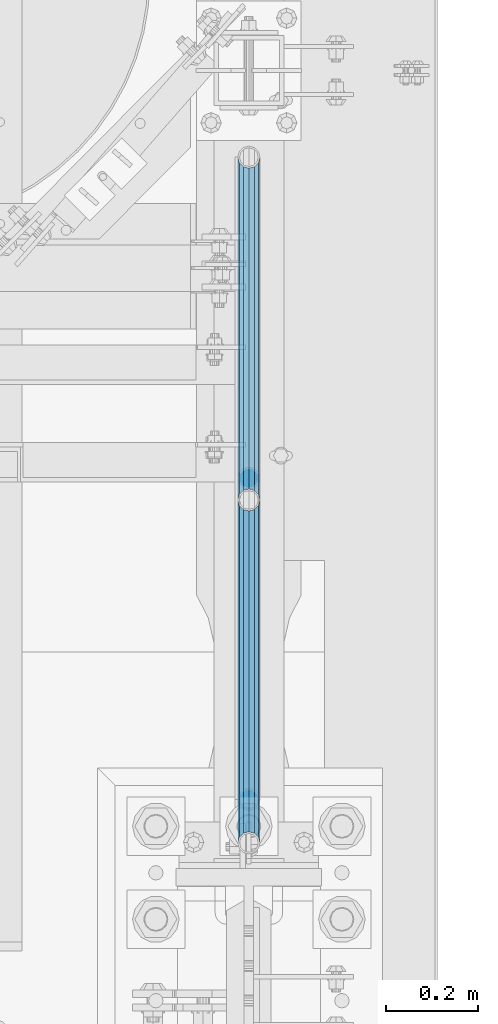
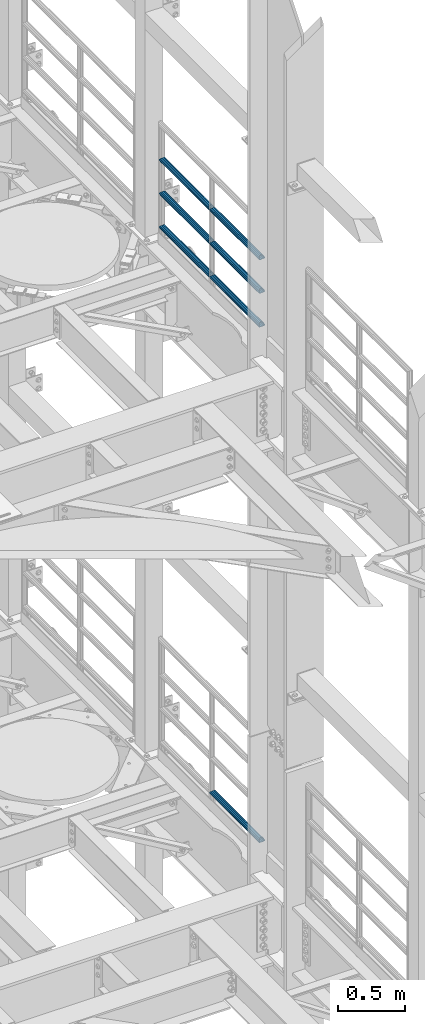
# One storey, part 1274 of 1876: 7 beams, 2 elements without a shape of their own.
"""IFC2X3 building model written with IfcOpenShell, lengths in millimetres."""

from ifc_helpers import new_model, si_unit, frame, origin_with_axes, place, context, subcontext, project, spatial, faceted_brep, material, type_object, element, aggregate, save


model = new_model("IFC2X3")

# Units and contexts
model_context = context("Model", 3, precision=1e-05, world=origin_with_axes())
body_context = subcontext(model_context, "Body", "Model", "MODEL_VIEW")
ifc_project = project(units=[si_unit("LENGTHUNIT", "METRE", prefix="MILLI"), si_unit("AREAUNIT", "SQUARE_METRE"), si_unit("VOLUMEUNIT", "CUBIC_METRE"), si_unit("MASSUNIT", "GRAM", prefix="KILO"), si_unit("TIMEUNIT", "SECOND"), si_unit("PLANEANGLEUNIT", "RADIAN"), si_unit("SOLIDANGLEUNIT", "STERADIAN"), si_unit("THERMODYNAMICTEMPERATUREUNIT", "DEGREE_CELSIUS"), si_unit("LUMINOUSINTENSITYUNIT", "LUMEN")], contexts=[model_context])

# Site, building, storey
site_placement = place(None, origin_with_axes())
site = spatial("IfcSite", under=ifc_project, at=site_placement, CompositionType="ELEMENT")
building_placement = place(site_placement, origin_with_axes())
building = spatial("IfcBuilding", under=site, at=building_placement, Name="Undefined", CompositionType="ELEMENT")
storey_placement = place(building_placement, origin_with_axes())
storey = spatial("IfcBuildingStorey", under=building, at=storey_placement, Name="Undefined", CompositionType="ELEMENT", Elevation=0.0)

# Assembly, beams
assembly_1_placement = place(storey_placement, origin_with_axes())
assembly_1 = element("IfcElementAssembly", 1, at=assembly_1_placement, inside=storey, Name="RAIL", AssemblyPlace="NOTDEFINED", PredefinedType="RIGID_FRAME")
ifc_material = material()
beam_type = type_object("IfcBeamType", Name="PIPE1-1/2SCH40", PredefinedType="NOTDEFINED")
beam_1_placement = place(assembly_1_placement, frame((7620.0, 2617.7875, 18145.125), z_axis=(0.0, 0.0, 1.0), x_axis=(0.0, -1.0, 0.0)))
beam_1 = element("IfcBeam", 2, at=beam_1_placement, type_object=beam_type, material=ifc_material, Name="RAIL", ObjectType="PIPE1-1/2SCH40", context=body_context, shape_type="Brep", body=[
    faceted_brep([(728.085307006683, -12.0649999999996, 20.8971929933177), (728.085307006683, -12.0649999999996, 15.8661214311796), (727.591878568821, -10.2235000000001, 17.7076214311819), (724.852500000002, 0.0, 20.4470000000001), (724.852500000002, 0.0, 24.130000000001), (727.591878568821, 10.2235000000001, 17.7076214311819), (728.085307006683, 12.0649999999996, 15.8661214311796), (728.085307006683, 12.0649999999996, 20.8971929933177), (748.982500000002, 24.1300000000001, 0.0), (736.917500000002, 20.8971929933186, 12.0649999999987), (736.917500000002, 20.8971929933186, -12.0649999999987), (733.727928437864, 17.7076214311801, 10.2235000000001), (736.467307006683, 20.4470000000001, 0.0), (733.727928437864, 17.7076214311801, -10.2235000000001), (728.085307006683, 12.0649999999996, -15.8661214311796), (728.085307006683, 12.0649999999996, -20.8971929933177), (727.591878568821, 10.2235000000001, -17.7076214311819), (724.852500000002, 0.0, -20.4470000000001), (724.852500000002, 0.0, -24.130000000001), (728.085307006683, -12.0649999999996, -15.8661214311796), (728.085307006683, -12.0649999999996, -20.8971929933177), (727.591878568821, -10.2235000000001, -17.7076214311819), (748.982500000002, -24.1300000000001, 0.0), (736.917500000002, -20.8971929933186, -12.0649999999987), (736.917500000002, -20.8971929933186, 12.0649999999987), (733.727928437864, -17.7076214311801, -10.2235000000001), (736.467307006683, -20.4470000000001, 0.0), (733.727928437864, -17.7076214311801, 10.2235000000001), (12.0650000000064, -20.8971929933177, -12.0649999999987), (20.8971929933249, -12.0650000000005, -20.8971929933177), (0.0, 24.1299999999992, 0.0), (12.0650000000064, 20.8971929933177, -12.0649999999987), (12.0650000000064, 20.8971929933177, 12.0649999999987), (20.8971929933249, 12.0650000000005, 20.8971929933177), (24.1300000000064, 0.0, 24.130000000001), (20.8971929933249, 12.0650000000005, -20.8971929933177), (24.1300000000063, 0.0, -24.130000000001), (24.1300000000063, 0.0, -20.4470000000001), (20.8971929933249, -12.0650000000005, -15.8661214311796), (21.3906214311868, -10.2235000000001, -17.7076214311819), (21.3906214311868, 10.2235000000001, -17.7076214311819), (20.8971929933249, 12.0650000000005, -15.8661214311796), (15.2545715621445, 17.7076214311801, -10.2235000000001), (12.5151929933249, 20.4470000000001, 0.0), (15.2545715621445, 17.7076214311801, 10.2235000000001), (20.8971929933249, 12.0650000000005, 15.8661214311796), (21.3906214311868, 10.2235000000001, 17.7076214311819), (24.1300000000064, 0.0, 20.4470000000001), (21.3906214311868, -10.2235000000001, 17.7076214311819), (20.8971929933249, -12.0650000000005, 15.8661214311796), (20.8971929933249, -12.0650000000005, 20.8971929933177), (12.0650000000064, -20.8971929933177, 12.0649999999987), (0.0, -24.1299999999992, 0.0), (15.2545715621445, -17.7076214311801, 10.2235000000001), (12.5151929933249, -20.4470000000001, 0.0), (15.2545715621445, -17.7076214311801, -10.2235000000001)], [[[0, 1, 2, 3, 4]], [[4, 3, 5, 6, 7]], [[8, 9, 10]], [[7, 6, 11, 12, 13, 14, 15, 10, 9]], [[16, 17, 18, 15, 14]], [[19, 20, 18, 17, 21]], [[22, 23, 24]], [[24, 23, 20, 19, 25, 26, 27, 1, 0]], [[28, 29, 20, 23]], [[30, 31, 32]], [[33, 34, 4, 7]], [[32, 33, 7, 9]], [[30, 32, 9, 8]], [[31, 30, 8, 10]], [[35, 31, 10, 15]], [[36, 35, 15, 18]], [[29, 36, 18, 20]], [[37, 36, 29, 38, 39]], [[40, 41, 35, 36, 37]], [[32, 31, 35, 41, 42, 43, 44, 45, 33]], [[33, 45, 46, 47, 34]], [[34, 47, 48, 49, 50]], [[34, 50, 0, 4]], [[50, 51, 24, 0]], [[51, 52, 22, 24]], [[52, 28, 23, 22]], [[51, 28, 52]], [[50, 49, 53, 54, 55, 38, 29, 28, 51]], [[55, 54, 26, 25]], [[21, 39, 38, 55, 25, 19]], [[37, 39, 21, 17]], [[40, 37, 17, 16]], [[42, 41, 40, 16, 14, 13]], [[43, 42, 13, 12]], [[44, 43, 12, 11]], [[5, 46, 45, 44, 11, 6]], [[47, 46, 5, 3]], [[48, 47, 3, 2]], [[53, 49, 48, 2, 1, 27]], [[54, 53, 27, 26]]]),
])
beam_2_placement = place(assembly_1_placement, frame((7620.0, 3366.77, 18145.125), z_axis=(0.0, 0.0, 1.0), x_axis=(0.0, -1.0, 0.0)))
beam_2 = element("IfcBeam", 3, at=beam_2_placement, type_object=beam_type, material=ifc_material, Name="RAIL", ObjectType="PIPE1-1/2SCH40", context=body_context, shape_type="Brep", body=[
    faceted_brep([(728.085307006683, -12.0649999999996, 20.8971929933177), (728.085307006683, -12.0649999999996, 15.8661214311796), (727.591878568821, -10.2235000000001, 17.7076214311819), (724.852500000002, 0.0, 20.4470000000001), (724.852500000002, 0.0, 24.130000000001), (727.591878568821, 10.2235000000001, 17.7076214311819), (728.085307006683, 12.0649999999996, 15.8661214311796), (728.085307006683, 12.0649999999996, 20.8971929933177), (748.982500000002, 24.1300000000001, 0.0), (736.917500000002, 20.8971929933186, 12.0649999999987), (736.917500000002, 20.8971929933186, -12.0649999999987), (733.727928437864, 17.7076214311801, 10.2235000000001), (736.467307006683, 20.4470000000001, 0.0), (733.727928437864, 17.7076214311801, -10.2235000000001), (728.085307006683, 12.0649999999996, -15.8661214311796), (728.085307006683, 12.0649999999996, -20.8971929933177), (727.591878568821, 10.2235000000001, -17.7076214311819), (724.852500000002, 0.0, -20.4470000000001), (724.852500000002, 0.0, -24.130000000001), (728.085307006683, -12.0649999999996, -15.8661214311796), (728.085307006683, -12.0649999999996, -20.8971929933177), (727.591878568821, -10.2235000000001, -17.7076214311819), (748.982500000002, -24.1300000000001, 0.0), (736.917500000002, -20.8971929933186, -12.0649999999987), (736.917500000002, -20.8971929933186, 12.0649999999987), (733.727928437864, -17.7076214311801, -10.2235000000001), (736.467307006683, -20.4470000000001, 0.0), (733.727928437864, -17.7076214311801, 10.2235000000001), (12.0650000000064, -20.8971929933177, -12.0649999999987), (20.8971929933249, -12.0650000000005, -20.8971929933177), (0.0, 24.1299999999992, 0.0), (12.0650000000064, 20.8971929933177, -12.0649999999987), (12.0650000000064, 20.8971929933177, 12.0649999999987), (20.8971929933249, 12.0650000000005, 20.8971929933177), (24.1300000000064, 0.0, 24.130000000001), (20.8971929933249, 12.0650000000005, -20.8971929933177), (24.1300000000063, 0.0, -24.130000000001), (24.1300000000063, 0.0, -20.4470000000001), (20.8971929933249, -12.0650000000005, -15.8661214311796), (21.3906214311868, -10.2235000000001, -17.7076214311819), (21.3906214311868, 10.2235000000001, -17.7076214311819), (20.8971929933249, 12.0650000000005, -15.8661214311796), (15.2545715621445, 17.7076214311801, -10.2235000000001), (12.5151929933249, 20.4470000000001, 0.0), (15.2545715621445, 17.7076214311801, 10.2235000000001), (20.8971929933249, 12.0650000000005, 15.8661214311796), (21.3906214311868, 10.2235000000001, 17.7076214311819), (24.1300000000064, 0.0, 20.4470000000001), (21.3906214311868, -10.2235000000001, 17.7076214311819), (20.8971929933249, -12.0650000000005, 15.8661214311796), (20.8971929933249, -12.0650000000005, 20.8971929933177), (12.0650000000064, -20.8971929933177, 12.0649999999987), (0.0, -24.1299999999992, 0.0), (15.2545715621445, -17.7076214311801, 10.2235000000001), (12.5151929933249, -20.4470000000001, 0.0), (15.2545715621445, -17.7076214311801, -10.2235000000001)], [[[0, 1, 2, 3, 4]], [[4, 3, 5, 6, 7]], [[8, 9, 10]], [[7, 6, 11, 12, 13, 14, 15, 10, 9]], [[16, 17, 18, 15, 14]], [[19, 20, 18, 17, 21]], [[22, 23, 24]], [[24, 23, 20, 19, 25, 26, 27, 1, 0]], [[28, 29, 20, 23]], [[30, 31, 32]], [[33, 34, 4, 7]], [[32, 33, 7, 9]], [[30, 32, 9, 8]], [[31, 30, 8, 10]], [[35, 31, 10, 15]], [[36, 35, 15, 18]], [[29, 36, 18, 20]], [[37, 36, 29, 38, 39]], [[40, 41, 35, 36, 37]], [[32, 31, 35, 41, 42, 43, 44, 45, 33]], [[33, 45, 46, 47, 34]], [[34, 47, 48, 49, 50]], [[34, 50, 0, 4]], [[50, 51, 24, 0]], [[51, 52, 22, 24]], [[52, 28, 23, 22]], [[51, 28, 52]], [[50, 49, 53, 54, 55, 38, 29, 28, 51]], [[55, 54, 26, 25]], [[21, 39, 38, 55, 25, 19]], [[37, 39, 21, 17]], [[40, 37, 17, 16]], [[42, 41, 40, 16, 14, 13]], [[43, 42, 13, 12]], [[44, 43, 12, 11]], [[5, 46, 45, 44, 11, 6]], [[47, 46, 5, 3]], [[48, 47, 3, 2]], [[53, 49, 48, 2, 1, 27]], [[54, 53, 27, 26]]]),
])
beam_3_placement = place(assembly_1_placement, frame((7620.0, 1868.805, 18449.925), z_axis=(0.0, 0.0, -1.0), x_axis=(0.0, 1.0, 0.0)))
beam_3 = element("IfcBeam", 4, at=beam_3_placement, type_object=beam_type, material=ifc_material, Name="RAIL", ObjectType="PIPE1-1/2SCH40", context=body_context, shape_type="Brep", body=[
    faceted_brep([(0.0, 24.1299999999992, 0.0), (12.0650000000064, 20.8971929933177, -12.0649999999987), (12.0650000000064, 20.8971929933177, 12.0649999999987), (12.0650000000064, -20.8971929933177, 12.0649999999987), (12.0650000000064, -20.8971929933177, -12.0649999999987), (0.0, -24.1299999999992, 0.0), (20.8971929933249, -12.0650000000005, 20.8971929933177), (20.8971929933249, -12.0650000000005, 15.8661214311796), (15.2545715621445, -17.7076214311801, 10.2235000000001), (12.5151929933249, -20.4470000000001, 0.0), (15.2545715621445, -17.7076214311801, -10.2235000000001), (20.8971929933249, -12.0650000000005, -15.8661214311796), (20.8971929933249, -12.0650000000005, -20.8971929933177), (24.1300000000063, 0.0, -20.4470000000001), (24.1300000000063, 0.0, -24.130000000001), (21.3906214311868, -10.2235000000001, -17.7076214311819), (21.3906214311868, 10.2235000000001, -17.7076214311819), (20.8971929933249, 12.0650000000005, -15.8661214311796), (20.8971929933249, 12.0650000000005, -20.8971929933177), (15.2545715621445, 17.7076214311801, -10.2235000000001), (12.5151929933249, 20.4470000000001, 0.0), (15.2545715621445, 17.7076214311801, 10.2235000000001), (20.8971929933249, 12.0650000000005, 15.8661214311796), (20.8971929933249, 12.0650000000005, 20.8971929933177), (21.3906214311868, 10.2235000000001, 17.7076214311819), (24.1300000000064, 0.0, 20.4470000000001), (24.1300000000064, 0.0, 24.130000000001), (21.3906214311868, -10.2235000000001, 17.7076214311819), (748.982500000002, 24.1300000000001, 0.0), (736.917500000002, 20.8971929933186, -12.0649999999987), (728.085307006683, 12.0649999999996, -20.8971929933177), (748.982500000002, -24.1300000000001, 0.0), (736.917500000002, -20.8971929933186, -12.0649999999987), (736.917500000002, -20.8971929933186, 12.0649999999987), (728.085307006683, -12.0649999999996, 20.8971929933177), (728.085307006683, -12.0649999999996, -20.8971929933177), (724.852500000002, 0.0, -24.130000000001), (727.591878568821, 10.2235000000001, -17.7076214311819), (724.852500000002, 0.0, -20.4470000000001), (728.085307006683, 12.0649999999996, -15.8661214311796), (728.085307006683, -12.0649999999996, -15.8661214311796), (727.591878568821, -10.2235000000001, -17.7076214311819), (733.727928437864, -17.7076214311801, -10.2235000000001), (736.467307006683, -20.4470000000001, 0.0), (733.727928437864, -17.7076214311801, 10.2235000000001), (728.085307006683, -12.0649999999996, 15.8661214311796), (727.591878568821, -10.2235000000001, 17.7076214311819), (724.852500000002, 0.0, 20.4470000000001), (724.852500000002, 0.0, 24.130000000001), (728.085307006683, 12.0649999999996, 20.8971929933177), (736.917500000002, 20.8971929933186, 12.0649999999987), (728.085307006683, 12.0649999999996, 15.8661214311796), (733.727928437864, 17.7076214311801, 10.2235000000001), (736.467307006683, 20.4470000000001, 0.0), (733.727928437864, 17.7076214311801, -10.2235000000001), (727.591878568821, 10.2235000000001, 17.7076214311819)], [[[0, 1, 2]], [[3, 4, 5]], [[6, 7, 8, 9, 10, 11, 12, 4, 3]], [[13, 14, 12, 11, 15]], [[16, 17, 18, 14, 13]], [[2, 1, 18, 17, 19, 20, 21, 22, 23]], [[23, 22, 24, 25, 26]], [[26, 25, 27, 7, 6]], [[1, 0, 28, 29]], [[18, 1, 29, 30]], [[31, 32, 33]], [[6, 3, 33, 34]], [[3, 5, 31, 33]], [[5, 4, 32, 31]], [[4, 12, 35, 32]], [[12, 14, 36, 35]], [[14, 18, 30, 36]], [[37, 38, 36, 30, 39]], [[40, 35, 36, 38, 41]], [[33, 32, 35, 40, 42, 43, 44, 45, 34]], [[34, 45, 46, 47, 48]], [[26, 6, 34, 48]], [[2, 23, 49, 50]], [[23, 26, 48, 49]], [[0, 2, 50, 28]], [[28, 50, 29]], [[49, 51, 52, 53, 54, 39, 30, 29, 50]], [[48, 47, 55, 51, 49]], [[25, 24, 55, 47]], [[55, 24, 22, 21, 52, 51]], [[21, 20, 53, 52]], [[20, 19, 54, 53]], [[19, 17, 16, 37, 39, 54]], [[16, 13, 38, 37]], [[13, 15, 41, 38]], [[41, 15, 11, 10, 42, 40]], [[10, 9, 43, 42]], [[9, 8, 44, 43]], [[8, 7, 27, 46, 45, 44]], [[27, 25, 47, 46]]]),
])
beam_4_placement = place(assembly_1_placement, frame((7620.0, 2617.7875, 18449.925), z_axis=(0.0, 0.0, -1.0), x_axis=(0.0, 1.0, 0.0)))
beam_4 = element("IfcBeam", 5, at=beam_4_placement, type_object=beam_type, material=ifc_material, Name="RAIL", ObjectType="PIPE1-1/2SCH40", context=body_context, shape_type="Brep", body=[
    faceted_brep([(0.0, 24.1299999999992, 0.0), (12.0650000000064, 20.8971929933177, -12.0649999999987), (12.0650000000064, 20.8971929933177, 12.0649999999987), (12.0650000000064, -20.8971929933177, 12.0649999999987), (12.0650000000064, -20.8971929933177, -12.0649999999987), (0.0, -24.1299999999992, 0.0), (20.8971929933249, -12.0650000000005, 20.8971929933177), (20.8971929933249, -12.0650000000005, 15.8661214311796), (15.2545715621445, -17.7076214311801, 10.2235000000001), (12.5151929933249, -20.4470000000001, 0.0), (15.2545715621445, -17.7076214311801, -10.2235000000001), (20.8971929933249, -12.0650000000005, -15.8661214311796), (20.8971929933249, -12.0650000000005, -20.8971929933177), (24.1300000000063, 0.0, -20.4470000000001), (24.1300000000063, 0.0, -24.130000000001), (21.3906214311868, -10.2235000000001, -17.7076214311819), (21.3906214311868, 10.2235000000001, -17.7076214311819), (20.8971929933249, 12.0650000000005, -15.8661214311796), (20.8971929933249, 12.0650000000005, -20.8971929933177), (15.2545715621445, 17.7076214311801, -10.2235000000001), (12.5151929933249, 20.4470000000001, 0.0), (15.2545715621445, 17.7076214311801, 10.2235000000001), (20.8971929933249, 12.0650000000005, 15.8661214311796), (20.8971929933249, 12.0650000000005, 20.8971929933177), (21.3906214311868, 10.2235000000001, 17.7076214311819), (24.1300000000064, 0.0, 20.4470000000001), (24.1300000000064, 0.0, 24.130000000001), (21.3906214311868, -10.2235000000001, 17.7076214311819), (748.982500000002, 24.1300000000001, 0.0), (736.917500000002, 20.8971929933186, -12.0649999999987), (728.085307006683, 12.0649999999996, -20.8971929933177), (748.982500000002, -24.1300000000001, 0.0), (736.917500000002, -20.8971929933186, -12.0649999999987), (736.917500000002, -20.8971929933186, 12.0649999999987), (728.085307006683, -12.0649999999996, 20.8971929933177), (728.085307006683, -12.0649999999996, -20.8971929933177), (724.852500000002, 0.0, -24.130000000001), (727.591878568821, 10.2235000000001, -17.7076214311819), (724.852500000002, 0.0, -20.4470000000001), (728.085307006683, 12.0649999999996, -15.8661214311796), (728.085307006683, -12.0649999999996, -15.8661214311796), (727.591878568821, -10.2235000000001, -17.7076214311819), (733.727928437864, -17.7076214311801, -10.2235000000001), (736.467307006683, -20.4470000000001, 0.0), (733.727928437864, -17.7076214311801, 10.2235000000001), (728.085307006683, -12.0649999999996, 15.8661214311796), (727.591878568821, -10.2235000000001, 17.7076214311819), (724.852500000002, 0.0, 20.4470000000001), (724.852500000002, 0.0, 24.130000000001), (728.085307006683, 12.0649999999996, 20.8971929933177), (736.917500000002, 20.8971929933186, 12.0649999999987), (728.085307006683, 12.0649999999996, 15.8661214311796), (733.727928437864, 17.7076214311801, 10.2235000000001), (736.467307006683, 20.4470000000001, 0.0), (733.727928437864, 17.7076214311801, -10.2235000000001), (727.591878568821, 10.2235000000001, 17.7076214311819)], [[[0, 1, 2]], [[3, 4, 5]], [[6, 7, 8, 9, 10, 11, 12, 4, 3]], [[13, 14, 12, 11, 15]], [[16, 17, 18, 14, 13]], [[2, 1, 18, 17, 19, 20, 21, 22, 23]], [[23, 22, 24, 25, 26]], [[26, 25, 27, 7, 6]], [[1, 0, 28, 29]], [[18, 1, 29, 30]], [[31, 32, 33]], [[6, 3, 33, 34]], [[3, 5, 31, 33]], [[5, 4, 32, 31]], [[4, 12, 35, 32]], [[12, 14, 36, 35]], [[14, 18, 30, 36]], [[37, 38, 36, 30, 39]], [[40, 35, 36, 38, 41]], [[33, 32, 35, 40, 42, 43, 44, 45, 34]], [[34, 45, 46, 47, 48]], [[26, 6, 34, 48]], [[2, 23, 49, 50]], [[23, 26, 48, 49]], [[0, 2, 50, 28]], [[28, 50, 29]], [[49, 51, 52, 53, 54, 39, 30, 29, 50]], [[48, 47, 55, 51, 49]], [[25, 24, 55, 47]], [[55, 24, 22, 21, 52, 51]], [[21, 20, 53, 52]], [[20, 19, 54, 53]], [[19, 17, 16, 37, 39, 54]], [[16, 13, 38, 37]], [[13, 15, 41, 38]], [[41, 15, 11, 10, 42, 40]], [[10, 9, 43, 42]], [[9, 8, 44, 43]], [[8, 7, 27, 46, 45, 44]], [[27, 25, 47, 46]]]),
])
beam_5_placement = place(assembly_1_placement, frame((7620.0, 1868.805, 18754.725), z_axis=(0.0, 0.0, -1.0), x_axis=(0.0, 1.0, 0.0)))
beam_5 = element("IfcBeam", 6, at=beam_5_placement, type_object=beam_type, material=ifc_material, Name="RAIL", ObjectType="PIPE1-1/2SCH40", context=body_context, shape_type="Brep", body=[
    faceted_brep([(0.0, 24.1299999999992, 0.0), (12.0650000000064, 20.8971929933177, -12.0649999999987), (12.0650000000064, 20.8971929933177, 12.0649999999987), (12.0650000000064, -20.8971929933177, 12.0649999999987), (12.0650000000064, -20.8971929933177, -12.0649999999987), (0.0, -24.1299999999992, 0.0), (20.8971929933249, -12.0650000000005, 20.8971929933177), (20.8971929933249, -12.0650000000005, 15.8661214311796), (15.2545715621445, -17.7076214311801, 10.2235000000001), (12.5151929933249, -20.4470000000001, 0.0), (15.2545715621445, -17.7076214311801, -10.2235000000001), (20.8971929933249, -12.0650000000005, -15.8661214311796), (20.8971929933249, -12.0650000000005, -20.8971929933177), (24.1300000000063, 0.0, -20.4470000000001), (24.1300000000063, 0.0, -24.130000000001), (21.3906214311868, -10.2235000000001, -17.7076214311819), (21.3906214311868, 10.2235000000001, -17.7076214311819), (20.8971929933249, 12.0650000000005, -15.8661214311796), (20.8971929933249, 12.0650000000005, -20.8971929933177), (15.2545715621445, 17.7076214311801, -10.2235000000001), (12.5151929933249, 20.4470000000001, 0.0), (15.2545715621445, 17.7076214311801, 10.2235000000001), (20.8971929933249, 12.0650000000005, 15.8661214311796), (20.8971929933249, 12.0650000000005, 20.8971929933177), (21.3906214311868, 10.2235000000001, 17.7076214311819), (24.1300000000064, 0.0, 20.4470000000001), (24.1300000000064, 0.0, 24.130000000001), (21.3906214311868, -10.2235000000001, 17.7076214311819), (748.982500000002, 24.1300000000001, 0.0), (736.917500000002, 20.8971929933186, -12.0649999999987), (728.085307006683, 12.0649999999996, -20.8971929933177), (748.982500000002, -24.1300000000001, 0.0), (736.917500000002, -20.8971929933186, -12.0649999999987), (736.917500000002, -20.8971929933186, 12.0649999999987), (728.085307006683, -12.0649999999996, 20.8971929933177), (728.085307006683, -12.0649999999996, -20.8971929933177), (724.852500000002, 0.0, -24.130000000001), (727.591878568821, 10.2235000000001, -17.7076214311819), (724.852500000002, 0.0, -20.4470000000001), (728.085307006683, 12.0649999999996, -15.8661214311796), (728.085307006683, -12.0649999999996, -15.8661214311796), (727.591878568821, -10.2235000000001, -17.7076214311819), (733.727928437864, -17.7076214311801, -10.2235000000001), (736.467307006683, -20.4470000000001, 0.0), (733.727928437864, -17.7076214311801, 10.2235000000001), (728.085307006683, -12.0649999999996, 15.8661214311796), (727.591878568821, -10.2235000000001, 17.7076214311819), (724.852500000002, 0.0, 20.4470000000001), (724.852500000002, 0.0, 24.130000000001), (728.085307006683, 12.0649999999996, 20.8971929933177), (736.917500000002, 20.8971929933186, 12.0649999999987), (728.085307006683, 12.0649999999996, 15.8661214311796), (733.727928437864, 17.7076214311801, 10.2235000000001), (736.467307006683, 20.4470000000001, 0.0), (733.727928437864, 17.7076214311801, -10.2235000000001), (727.591878568821, 10.2235000000001, 17.7076214311819)], [[[0, 1, 2]], [[3, 4, 5]], [[6, 7, 8, 9, 10, 11, 12, 4, 3]], [[13, 14, 12, 11, 15]], [[16, 17, 18, 14, 13]], [[2, 1, 18, 17, 19, 20, 21, 22, 23]], [[23, 22, 24, 25, 26]], [[26, 25, 27, 7, 6]], [[1, 0, 28, 29]], [[18, 1, 29, 30]], [[31, 32, 33]], [[6, 3, 33, 34]], [[3, 5, 31, 33]], [[5, 4, 32, 31]], [[4, 12, 35, 32]], [[12, 14, 36, 35]], [[14, 18, 30, 36]], [[37, 38, 36, 30, 39]], [[40, 35, 36, 38, 41]], [[33, 32, 35, 40, 42, 43, 44, 45, 34]], [[34, 45, 46, 47, 48]], [[26, 6, 34, 48]], [[2, 23, 49, 50]], [[23, 26, 48, 49]], [[0, 2, 50, 28]], [[28, 50, 29]], [[49, 51, 52, 53, 54, 39, 30, 29, 50]], [[48, 47, 55, 51, 49]], [[25, 24, 55, 47]], [[55, 24, 22, 21, 52, 51]], [[21, 20, 53, 52]], [[20, 19, 54, 53]], [[19, 17, 16, 37, 39, 54]], [[16, 13, 38, 37]], [[13, 15, 41, 38]], [[41, 15, 11, 10, 42, 40]], [[10, 9, 43, 42]], [[9, 8, 44, 43]], [[8, 7, 27, 46, 45, 44]], [[27, 25, 47, 46]]]),
])
beam_6_placement = place(assembly_1_placement, frame((7620.0, 2617.7875, 18754.725), z_axis=(0.0, 0.0, -1.0), x_axis=(0.0, 1.0, 0.0)))
beam_6 = element("IfcBeam", 7, at=beam_6_placement, type_object=beam_type, material=ifc_material, Name="RAIL", ObjectType="PIPE1-1/2SCH40", context=body_context, shape_type="Brep", body=[
    faceted_brep([(0.0, 24.1299999999992, 0.0), (12.0650000000064, 20.8971929933177, -12.0649999999987), (12.0650000000064, 20.8971929933177, 12.0649999999987), (12.0650000000064, -20.8971929933177, 12.0649999999987), (12.0650000000064, -20.8971929933177, -12.0649999999987), (0.0, -24.1299999999992, 0.0), (20.8971929933249, -12.0650000000005, 20.8971929933177), (20.8971929933249, -12.0650000000005, 15.8661214311796), (15.2545715621445, -17.7076214311801, 10.2235000000001), (12.5151929933249, -20.4470000000001, 0.0), (15.2545715621445, -17.7076214311801, -10.2235000000001), (20.8971929933249, -12.0650000000005, -15.8661214311796), (20.8971929933249, -12.0650000000005, -20.8971929933177), (24.1300000000063, 0.0, -20.4470000000001), (24.1300000000063, 0.0, -24.130000000001), (21.3906214311868, -10.2235000000001, -17.7076214311819), (21.3906214311868, 10.2235000000001, -17.7076214311819), (20.8971929933249, 12.0650000000005, -15.8661214311796), (20.8971929933249, 12.0650000000005, -20.8971929933177), (15.2545715621445, 17.7076214311801, -10.2235000000001), (12.5151929933249, 20.4470000000001, 0.0), (15.2545715621445, 17.7076214311801, 10.2235000000001), (20.8971929933249, 12.0650000000005, 15.8661214311796), (20.8971929933249, 12.0650000000005, 20.8971929933177), (21.3906214311868, 10.2235000000001, 17.7076214311819), (24.1300000000064, 0.0, 20.4470000000001), (24.1300000000064, 0.0, 24.130000000001), (21.3906214311868, -10.2235000000001, 17.7076214311819), (748.982500000002, 24.1300000000001, 0.0), (736.917500000002, 20.8971929933186, -12.0649999999987), (728.085307006683, 12.0649999999996, -20.8971929933177), (748.982500000002, -24.1300000000001, 0.0), (736.917500000002, -20.8971929933186, -12.0649999999987), (736.917500000002, -20.8971929933186, 12.0649999999987), (728.085307006683, -12.0649999999996, 20.8971929933177), (728.085307006683, -12.0649999999996, -20.8971929933177), (724.852500000002, 0.0, -24.130000000001), (727.591878568821, 10.2235000000001, -17.7076214311819), (724.852500000002, 0.0, -20.4470000000001), (728.085307006683, 12.0649999999996, -15.8661214311796), (728.085307006683, -12.0649999999996, -15.8661214311796), (727.591878568821, -10.2235000000001, -17.7076214311819), (733.727928437864, -17.7076214311801, -10.2235000000001), (736.467307006683, -20.4470000000001, 0.0), (733.727928437864, -17.7076214311801, 10.2235000000001), (728.085307006683, -12.0649999999996, 15.8661214311796), (727.591878568821, -10.2235000000001, 17.7076214311819), (724.852500000002, 0.0, 20.4470000000001), (724.852500000002, 0.0, 24.130000000001), (728.085307006683, 12.0649999999996, 20.8971929933177), (736.917500000002, 20.8971929933186, 12.0649999999987), (728.085307006683, 12.0649999999996, 15.8661214311796), (733.727928437864, 17.7076214311801, 10.2235000000001), (736.467307006683, 20.4470000000001, 0.0), (733.727928437864, 17.7076214311801, -10.2235000000001), (727.591878568821, 10.2235000000001, 17.7076214311819)], [[[0, 1, 2]], [[3, 4, 5]], [[6, 7, 8, 9, 10, 11, 12, 4, 3]], [[13, 14, 12, 11, 15]], [[16, 17, 18, 14, 13]], [[2, 1, 18, 17, 19, 20, 21, 22, 23]], [[23, 22, 24, 25, 26]], [[26, 25, 27, 7, 6]], [[1, 0, 28, 29]], [[18, 1, 29, 30]], [[31, 32, 33]], [[6, 3, 33, 34]], [[3, 5, 31, 33]], [[5, 4, 32, 31]], [[4, 12, 35, 32]], [[12, 14, 36, 35]], [[14, 18, 30, 36]], [[37, 38, 36, 30, 39]], [[40, 35, 36, 38, 41]], [[33, 32, 35, 40, 42, 43, 44, 45, 34]], [[34, 45, 46, 47, 48]], [[26, 6, 34, 48]], [[2, 23, 49, 50]], [[23, 26, 48, 49]], [[0, 2, 50, 28]], [[28, 50, 29]], [[49, 51, 52, 53, 54, 39, 30, 29, 50]], [[48, 47, 55, 51, 49]], [[25, 24, 55, 47]], [[55, 24, 22, 21, 52, 51]], [[21, 20, 53, 52]], [[20, 19, 54, 53]], [[19, 17, 16, 37, 39, 54]], [[16, 13, 38, 37]], [[13, 15, 41, 38]], [[41, 15, 11, 10, 42, 40]], [[10, 9, 43, 42]], [[9, 8, 44, 43]], [[8, 7, 27, 46, 45, 44]], [[27, 25, 47, 46]]]),
])
aggregate(assembly_1, [beam_1, beam_2, beam_3, beam_4, beam_5, beam_6])

# Assembly, beam
assembly_2_placement = place(storey_placement, origin_with_axes())
assembly_2 = element("IfcElementAssembly", 8, at=assembly_2_placement, inside=storey, Name="RAIL", AssemblyPlace="NOTDEFINED", PredefinedType="RIGID_FRAME")
beam_7_placement = place(assembly_2_placement, frame((7620.0, 2617.7875, 13471.525), z_axis=(0.0, 0.0, 1.0), x_axis=(0.0, -1.0, 0.0)))
beam_7 = element("IfcBeam", 9, at=beam_7_placement, type_object=beam_type, material=ifc_material, Name="RAIL", ObjectType="PIPE1-1/2SCH40", context=body_context, shape_type="Brep", body=[
    faceted_brep([(728.085307006683, -12.0649999999996, 20.8971929933177), (728.085307006683, -12.0649999999996, 15.8661214311796), (727.591878568821, -10.2235000000001, 17.7076214311819), (724.852500000002, 0.0, 20.4470000000001), (724.852500000002, 0.0, 24.130000000001), (727.591878568821, 10.2235000000001, 17.7076214311819), (728.085307006683, 12.0649999999996, 15.8661214311796), (728.085307006683, 12.0649999999996, 20.8971929933177), (748.982500000002, 24.1300000000001, 0.0), (736.917500000002, 20.8971929933186, 12.0649999999987), (736.917500000002, 20.8971929933186, -12.0649999999987), (733.727928437864, 17.7076214311801, 10.2235000000001), (736.467307006683, 20.4470000000001, 0.0), (733.727928437864, 17.7076214311801, -10.2235000000001), (728.085307006683, 12.0649999999996, -15.8661214311796), (728.085307006683, 12.0649999999996, -20.8971929933177), (727.591878568821, 10.2235000000001, -17.7076214311819), (724.852500000002, 0.0, -20.4470000000001), (724.852500000002, 0.0, -24.130000000001), (728.085307006683, -12.0649999999996, -15.8661214311796), (728.085307006683, -12.0649999999996, -20.8971929933177), (727.591878568821, -10.2235000000001, -17.7076214311819), (748.982500000002, -24.1300000000001, 0.0), (736.917500000002, -20.8971929933186, -12.0649999999987), (736.917500000002, -20.8971929933186, 12.0649999999987), (733.727928437864, -17.7076214311801, -10.2235000000001), (736.467307006683, -20.4470000000001, 0.0), (733.727928437864, -17.7076214311801, 10.2235000000001), (12.0650000000064, -20.8971929933177, -12.0649999999987), (20.8971929933249, -12.0650000000005, -20.8971929933177), (0.0, 24.1299999999992, 0.0), (12.0650000000064, 20.8971929933177, -12.0649999999987), (12.0650000000064, 20.8971929933177, 12.0649999999987), (20.8971929933249, 12.0650000000005, 20.8971929933177), (24.1300000000064, 0.0, 24.130000000001), (20.8971929933249, 12.0650000000005, -20.8971929933177), (24.1300000000063, 0.0, -24.130000000001), (24.1300000000063, 0.0, -20.4470000000001), (20.8971929933249, -12.0650000000005, -15.8661214311796), (21.3906214311868, -10.2235000000001, -17.7076214311819), (21.3906214311868, 10.2235000000001, -17.7076214311819), (20.8971929933249, 12.0650000000005, -15.8661214311796), (15.2545715621445, 17.7076214311801, -10.2235000000001), (12.5151929933249, 20.4470000000001, 0.0), (15.2545715621445, 17.7076214311801, 10.2235000000001), (20.8971929933249, 12.0650000000005, 15.8661214311796), (21.3906214311868, 10.2235000000001, 17.7076214311819), (24.1300000000064, 0.0, 20.4470000000001), (21.3906214311868, -10.2235000000001, 17.7076214311819), (20.8971929933249, -12.0650000000005, 15.8661214311796), (20.8971929933249, -12.0650000000005, 20.8971929933177), (12.0650000000064, -20.8971929933177, 12.0649999999987), (0.0, -24.1299999999992, 0.0), (15.2545715621445, -17.7076214311801, 10.2235000000001), (12.5151929933249, -20.4470000000001, 0.0), (15.2545715621445, -17.7076214311801, -10.2235000000001)], [[[0, 1, 2, 3, 4]], [[4, 3, 5, 6, 7]], [[8, 9, 10]], [[7, 6, 11, 12, 13, 14, 15, 10, 9]], [[16, 17, 18, 15, 14]], [[19, 20, 18, 17, 21]], [[22, 23, 24]], [[24, 23, 20, 19, 25, 26, 27, 1, 0]], [[28, 29, 20, 23]], [[30, 31, 32]], [[33, 34, 4, 7]], [[32, 33, 7, 9]], [[30, 32, 9, 8]], [[31, 30, 8, 10]], [[35, 31, 10, 15]], [[36, 35, 15, 18]], [[29, 36, 18, 20]], [[37, 36, 29, 38, 39]], [[40, 41, 35, 36, 37]], [[32, 31, 35, 41, 42, 43, 44, 45, 33]], [[33, 45, 46, 47, 34]], [[34, 47, 48, 49, 50]], [[34, 50, 0, 4]], [[50, 51, 24, 0]], [[51, 52, 22, 24]], [[52, 28, 23, 22]], [[51, 28, 52]], [[50, 49, 53, 54, 55, 38, 29, 28, 51]], [[55, 54, 26, 25]], [[21, 39, 38, 55, 25, 19]], [[37, 39, 21, 17]], [[40, 37, 17, 16]], [[42, 41, 40, 16, 14, 13]], [[43, 42, 13, 12]], [[44, 43, 12, 11]], [[5, 46, 45, 44, 11, 6]], [[47, 46, 5, 3]], [[48, 47, 3, 2]], [[53, 49, 48, 2, 1, 27]], [[54, 53, 27, 26]]]),
])
aggregate(assembly_2, [beam_7])

save(model, "model.ifc")
